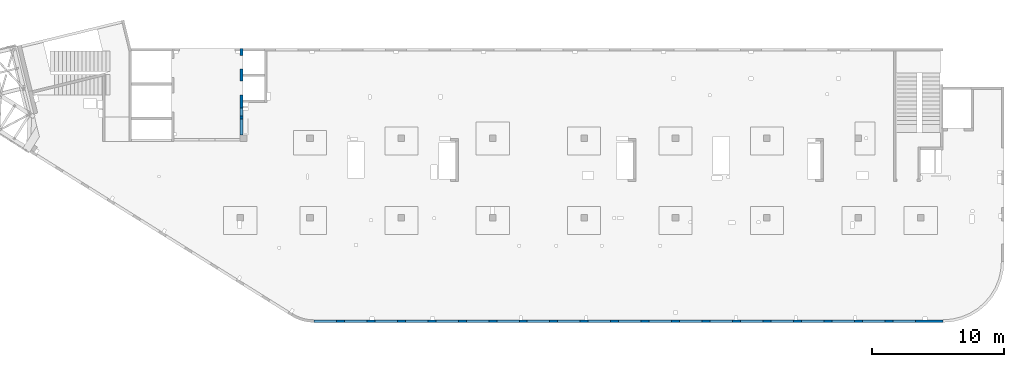
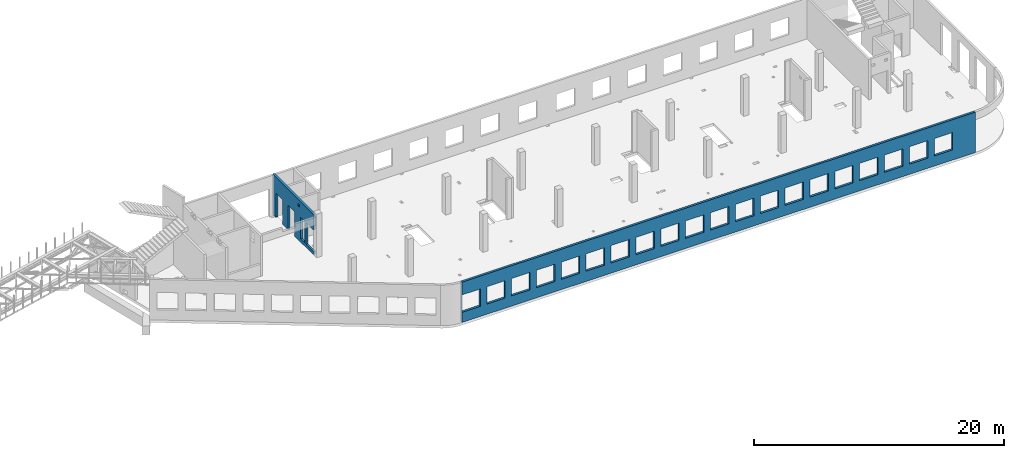
# One storey, part 65 of 66: 2 walls, 25 openings.
"""IFC4 building model written with IfcOpenShell, lengths in millimetres."""

from ifc_helpers import new_model, entity, si_unit, converted_unit, derived_unit, direction, frame, origin, place, context, subcontext, project, spatial, indexed_curve, outline, extrude, polygons, material, type_object, element, save


model = new_model("IFC4")

# Units and contexts
model_context = context("Model", 3, precision=0.01, world=origin(), true_north=direction((6.12303176911189e-17, 1.0)))
plan_context = context("Plan", 3, precision=0.01, world=origin(), true_north=direction((6.12303176911189e-17, 1.0)))
body_context = subcontext(model_context, "Body", "Model", "MODEL_VIEW")
ifc_project = project(units=[si_unit("LENGTHUNIT", "METRE", prefix="MILLI"), si_unit("AREAUNIT", "SQUARE_METRE"), si_unit("VOLUMEUNIT", "CUBIC_METRE"), converted_unit("PLANEANGLEUNIT", "DEGREE", entity("IfcRatioMeasure", 0.0174532925199433), si_unit("PLANEANGLEUNIT", "RADIAN"), dimensions=[0, 0, 0, 0, 0, 0, 0]), si_unit("MASSUNIT", "GRAM", prefix="KILO"), derived_unit("MASSDENSITYUNIT", [(si_unit("MASSUNIT", "GRAM", prefix="KILO"), 1), (si_unit("LENGTHUNIT", "METRE"), -3)]), derived_unit("MOMENTOFINERTIAUNIT", [(si_unit("LENGTHUNIT", "METRE"), 4)]), si_unit("TIMEUNIT", "SECOND"), si_unit("FREQUENCYUNIT", "HERTZ"), si_unit("THERMODYNAMICTEMPERATUREUNIT", "DEGREE_CELSIUS"), derived_unit("THERMALTRANSMITTANCEUNIT", [(si_unit("MASSUNIT", "GRAM", prefix="KILO"), 1), (si_unit("THERMODYNAMICTEMPERATUREUNIT", "KELVIN"), -1), (si_unit("TIMEUNIT", "SECOND"), -3)]), derived_unit("VOLUMETRICFLOWRATEUNIT", [(si_unit("LENGTHUNIT", "METRE"), 3), (si_unit("TIMEUNIT", "SECOND"), -1)]), derived_unit("MASSFLOWRATEUNIT", [(si_unit("MASSUNIT", "GRAM", prefix="KILO"), 1), (si_unit("TIMEUNIT", "SECOND"), -1)]), derived_unit("ROTATIONALFREQUENCYUNIT", [(si_unit("TIMEUNIT", "SECOND"), -1)]), si_unit("ELECTRICCURRENTUNIT", "AMPERE"), si_unit("ELECTRICVOLTAGEUNIT", "VOLT"), si_unit("POWERUNIT", "WATT"), si_unit("FORCEUNIT", "NEWTON", prefix="KILO"), si_unit("ILLUMINANCEUNIT", "LUX"), si_unit("LUMINOUSFLUXUNIT", "LUMEN"), si_unit("LUMINOUSINTENSITYUNIT", "CANDELA"), derived_unit("USERDEFINED", [(si_unit("MASSUNIT", "GRAM", prefix="KILO"), -1), (si_unit("LENGTHUNIT", "METRE"), -2), (si_unit("TIMEUNIT", "SECOND"), 3), (si_unit("LUMINOUSFLUXUNIT", "LUMEN"), 1)]), derived_unit("LINEARVELOCITYUNIT", [(si_unit("LENGTHUNIT", "METRE"), 1), (si_unit("TIMEUNIT", "SECOND"), -1)]), si_unit("PRESSUREUNIT", "PASCAL"), derived_unit("USERDEFINED", [(si_unit("LENGTHUNIT", "METRE"), -2), (si_unit("MASSUNIT", "GRAM", prefix="KILO"), 1), (si_unit("TIMEUNIT", "SECOND"), -2)]), derived_unit("LINEARFORCEUNIT", [(si_unit("MASSUNIT", "GRAM", prefix="KILO"), 1), (si_unit("LENGTHUNIT", "METRE"), 1), (si_unit("TIMEUNIT", "SECOND"), -2), (si_unit("LENGTHUNIT", "METRE"), -1)]), derived_unit("PLANARFORCEUNIT", [(si_unit("MASSUNIT", "GRAM", prefix="KILO"), 1), (si_unit("LENGTHUNIT", "METRE"), 1), (si_unit("TIMEUNIT", "SECOND"), -2), (si_unit("LENGTHUNIT", "METRE"), -2)])], contexts=[model_context, plan_context])

# Site, building, storey
site_placement = place(None, origin())
site = spatial("IfcSite", under=ifc_project, at=site_placement, CompositionType="ELEMENT")
building_placement = place(site_placement, origin())
building = spatial("IfcBuilding", under=site, at=building_placement, CompositionType="ELEMENT")
storey_placement = place(building_placement, frame((0.0, 0.0, 19800.0)))
storey = spatial("IfcBuildingStorey", under=building, at=storey_placement, Name="06", CompositionType="ELEMENT", Elevation=19800.0)

# Wall, openings
ifc_material = material()
wall_type = type_object("IfcWallType", Name=":ADSK_ 25_200", PredefinedType="STANDARD")
wall_1_placement = place(storey_placement, frame((21465.0, -100.0, -150.0)))
wall_1 = element("IfcWall", 1, at=wall_1_placement, inside=storey, type_object=wall_type, material=ifc_material, Name=":ADSK_ 25_200", ObjectType=":ADSK_ 25_200", PredefinedType="NOTDEFINED", context=body_context, shape_type="Tessellation", body=[
    polygons([(43705.0, -100.0, 2700.0), (45405.0, -100.0, 2700.0), (45405.0, -100.0, 1000.00000000001), (43705.0, -100.0, 1000.00000000001), (41405.0, -100.0, 2700.0), (43105.0, -100.0, 2700.0), (43105.0, -100.0, 1000.00000000001), (41405.0, -100.0, 1000.00000000001), (39105.0, -100.0, 2700.0), (40805.0, -100.0, 2700.0), (40805.0, -100.0, 1000.00000000001), (39105.0, -100.0, 1000.00000000001), (36805.0, -100.0, 2700.0), (38505.0, -100.0, 2700.0), (38505.0, -100.0, 1000.00000000001), (36805.0, -100.0, 1000.00000000001), (34505.0, -100.0, 2700.0), (36205.0, -100.0, 2700.0), (36205.0, -100.0, 1000.00000000001), (34505.0, -100.0, 1000.00000000001), (27605.0, -100.0, 2700.0), (29305.0, -100.0, 2700.0), (29305.0, -100.0, 1000.00000000001), (27605.0, -100.0, 1000.00000000001), (29905.0, -100.0, 2700.0), (31605.0, -100.0, 2700.0), (31605.0, -100.0, 1000.00000000001), (29905.0, -100.0, 1000.00000000001), (32205.0, -100.0, 2700.0), (33905.0, -100.0, 2700.0), (33905.0, -100.0, 1000.00000000001), (32205.0, -100.0, 1000.00000000001), (20705.0, -100.0, 2700.0), (22405.0, -100.0, 2700.0), (22405.0, -100.0, 1000.00000000001), (20705.0, -100.0, 1000.00000000001), (23005.0, -100.0, 2700.0), (24705.0, -100.0, 2700.0), (24705.0, -100.0, 1000.00000000001), (23005.0, -100.0, 1000.00000000001), (25305.0, -100.0, 2700.0), (27005.0, -100.0, 2700.0), (27005.0, -100.0, 1000.00000000001), (25305.0, -100.0, 1000.00000000001), (13805.0, -100.0, 2700.0), (15505.0, -100.0, 2700.0), (15505.0, -100.0, 1000.00000000001), (13805.0, -100.0, 1000.00000000001), (16105.0, -100.0, 2700.0), (17805.0, -100.0, 2700.0), (17805.0, -100.0, 1000.00000000001), (16105.0, -100.0, 1000.00000000001), (18405.0, -100.0, 2700.0), (20105.0, -100.0, 2700.0), (20105.0, -100.0, 1000.00000000001), (18405.0, -100.0, 1000.00000000001), (6904.99999999999, -100.0, 2700.0), (8604.99999999999, -100.0, 2700.0), (8604.99999999999, -100.0, 1000.00000000001), (6904.99999999999, -100.0, 1000.00000000001), (9205.0, -100.0, 2700.0), (10905.0, -100.0, 2700.0), (10905.0, -100.0, 1000.00000000001), (9205.0, -100.0, 1000.00000000001), (11505.0, -100.0, 2700.0), (13205.0, -100.0, 2700.0), (13205.0, -100.0, 1000.00000000001), (11505.0, -100.0, 1000.00000000001), (2305.0, -100.0, 2700.0), (4005.0, -100.0, 2700.0), (4005.0, -100.0, 1000.00000000001), (2305.0, -100.0, 1000.00000000001), (4605.0, -100.0, 2700.0), (6305.00000000001, -100.0, 2700.0), (6305.00000000001, -100.0, 1000.00000000001), (4605.0, -100.0, 1000.00000000001), (5.00000000000384, -100.0, 2700.0), (1705.0, -100.0, 2700.0), (1705.0, -100.0, 1000.00000000001), (5.00000000000384, -100.0, 1000.00000000001), (6.46235172450444e-13, -100.0, 0.0), (47505.0, -100.0, 0.0), (47505.0, -100.0, 3950.0), (4.65284088467406, -100.0, 3950.0), (4.97770368964401e-12, -100.0, 3950.0), (45405.0, 100.000000000321, 2700.0), (43705.0, 100.000000000321, 2700.0), (43705.0, 100.000000000321, 1000.00000000001), (45405.0, 100.000000000321, 1000.00000000001), (43105.0, 100.000000000321, 2700.0), (41405.0, 100.000000000321, 2700.0), (41405.0, 100.000000000321, 1000.00000000001), (43105.0, 100.000000000321, 1000.00000000001), (40805.0, 100.000000000321, 2700.0), (39105.0, 100.000000000321, 2700.0), (39105.0, 100.000000000321, 1000.00000000001), (40805.0, 100.000000000321, 1000.00000000001), (38505.0, 100.000000000321, 2700.0), (36805.0, 100.000000000321, 2700.0), (36805.0, 100.000000000321, 1000.00000000001), (38505.0, 100.000000000321, 1000.00000000001), (36205.0, 100.000000000321, 2700.0), (34505.0, 100.000000000321, 2700.0), (34505.0, 100.000000000321, 1000.00000000001), (36205.0, 100.000000000321, 1000.00000000001), (29305.0, 100.000000000321, 2700.0), (27605.0, 100.000000000321, 2700.0), (27605.0, 100.000000000321, 1000.00000000001), (29305.0, 100.000000000321, 1000.00000000001), (31605.0, 100.000000000321, 2700.0), (29905.0, 100.000000000321, 2700.0), (29905.0, 100.000000000321, 1000.00000000001), (31605.0, 100.000000000321, 1000.00000000001), (33905.0, 100.000000000321, 2700.0), (32205.0, 100.000000000321, 2700.0), (32205.0, 100.000000000321, 1000.00000000001), (33905.0, 100.000000000321, 1000.00000000001), (22405.0, 100.000000000321, 2700.0), (20705.0, 100.000000000321, 2700.0), (20705.0, 100.000000000321, 1000.00000000001), (22405.0, 100.000000000321, 1000.00000000001), (24705.0, 100.000000000321, 2700.0), (23005.0, 100.000000000321, 2700.0), (23005.0, 100.000000000321, 1000.00000000001), (24705.0, 100.000000000321, 1000.00000000001), (27005.0, 100.000000000321, 2700.0), (25305.0, 100.000000000321, 2700.0), (25305.0, 100.000000000321, 1000.00000000001), (27005.0, 100.000000000321, 1000.00000000001), (15505.0, 100.000000000321, 2700.0), (13805.0, 100.000000000321, 2700.0), (13805.0, 100.000000000321, 1000.00000000001), (15505.0, 100.000000000321, 1000.00000000001), (17805.0, 100.000000000321, 2700.0), (16105.0, 100.000000000321, 2700.0), (16105.0, 100.000000000321, 1000.00000000001), (17805.0, 100.000000000321, 1000.00000000001), (20105.0, 100.000000000321, 2700.0), (18405.0, 100.000000000321, 2700.0), (18405.0, 100.000000000321, 1000.00000000001), (20105.0, 100.000000000321, 1000.00000000001), (8604.99999999998, 100.000000000321, 2700.0), (6904.99999999999, 100.000000000321, 2700.0), (6904.99999999999, 100.000000000321, 1000.00000000001), (8604.99999999998, 100.000000000321, 1000.00000000001), (10905.0, 100.000000000321, 2700.0), (9204.99999999999, 100.000000000321, 2700.0), (9204.99999999999, 100.000000000321, 1000.00000000001), (10905.0, 100.000000000321, 1000.00000000001), (13205.0, 100.000000000321, 2700.0), (11505.0, 100.000000000321, 2700.0), (11505.0, 100.000000000321, 1000.00000000001), (13205.0, 100.000000000321, 1000.00000000001), (4005.0, 100.000000000321, 2700.0), (2305.0, 100.000000000321, 2700.0), (2305.0, 100.000000000321, 1000.00000000001), (4005.0, 100.000000000321, 1000.00000000001), (6305.0, 100.000000000321, 2700.0), (4605.0, 100.000000000321, 2700.0), (4605.0, 100.000000000321, 1000.00000000001), (6305.0, 100.000000000321, 1000.00000000001), (1705.0, 100.000000000321, 2700.0), (5.00000000000319, 100.000000000321, 2700.0), (5.00000000000319, 100.000000000321, 1000.00000000002), (1705.0, 100.000000000321, 1000.00000000002), (47505.0, 100.0, 0.0), (46305.0, 100.0, 0.0), (46005.0, 100.0, 0.0), (40985.0, 100.0, 0.0), (40785.0, 100.0, 0.0), (36475.0, 100.0, 0.0), (36275.0, 100.0, 0.0), (31965.0, 100.0, 0.0), (31765.0, 100.0, 0.0), (20675.0, 100.0, 0.0), (20475.0, 100.0, 0.0), (15725.0, 100.0, 0.0), (15525.0, 100.0, 0.0), (9114.99999999999, 100.0, 0.0), (8814.99999999999, 100.0, 0.0), (4534.99999999999, 100.0, 0.0), (4234.99999999999, 100.0, 0.0), (2.49977157936766e-18, 100.0, 0.0), (4.33147101696515e-12, 100.0, 3950.0), (4234.99999999999, 100.0, 3950.0), (4535.0, 100.0, 3950.0), (8930.0, 100.0, 3950.0), (9130.0, 100.0, 3950.0), (13355.0, 100.0, 3950.0), (13655.0, 100.0, 3950.0), (18105.0, 100.0, 3950.0), (18405.0, 100.0, 3950.0), (24805.0, 100.0, 3950.0), (25105.0, 100.0, 3950.0), (31805.0, 100.0, 3950.0), (32105.0, 100.0, 3950.0), (36405.0, 100.0, 3950.0), (36705.0, 100.0, 3950.0), (41005.0, 100.0, 3950.0), (41305.0, 100.0, 3950.0), (46005.0, 100.0, 3950.0), (46305.0, 100.0, 3950.0), (47505.0, 100.0, 3950.0)], [[[81, 82, 83, 84, 85], [1, 2, 3, 4], [5, 6, 7, 8], [9, 10, 11, 12], [13, 14, 15, 16], [17, 18, 19, 20], [21, 22, 23, 24], [25, 26, 27, 28], [29, 30, 31, 32], [33, 34, 35, 36], [37, 38, 39, 40], [41, 42, 43, 44], [45, 46, 47, 48], [49, 50, 51, 52], [53, 54, 55, 56], [57, 58, 59, 60], [61, 62, 63, 64], [65, 66, 67, 68], [69, 70, 71, 72], [73, 74, 75, 76], [77, 78, 79, 80]], [[166, 167, 168, 169, 170, 171, 172, 173, 174, 175, 176, 177, 178, 179, 180, 181, 182, 183, 184, 185, 186, 187, 188, 189, 190, 191, 192, 193, 194, 195, 196, 197, 198, 199, 200, 201, 202, 203], [86, 87, 88, 89], [90, 91, 92, 93], [94, 95, 96, 97], [98, 99, 100, 101], [102, 103, 104, 105], [106, 107, 108, 109], [110, 111, 112, 113], [114, 115, 116, 117], [118, 119, 120, 121], [122, 123, 124, 125], [126, 127, 128, 129], [130, 131, 132, 133], [134, 135, 136, 137], [138, 139, 140, 141], [142, 143, 144, 145], [146, 147, 148, 149], [150, 151, 152, 153], [154, 155, 156, 157], [158, 159, 160, 161], [162, 163, 164, 165]], [[82, 81, 183, 182, 181, 180, 179, 178, 177, 176, 175, 174, 173, 172, 171, 170, 169, 168, 167, 166]], [[83, 82, 166, 203]], [[85, 84, 83, 203, 202, 201, 200, 199, 198, 197, 196, 195, 194, 193, 192, 191, 190, 189, 188, 187, 186, 185, 184]], [[81, 85, 184, 183]], [[87, 86, 2, 1]], [[87, 1, 4, 88]], [[88, 4, 3, 89]], [[2, 86, 89, 3]], [[91, 90, 6, 5]], [[91, 5, 8, 92]], [[92, 8, 7, 93]], [[6, 90, 93, 7]], [[95, 94, 10, 9]], [[95, 9, 12, 96]], [[96, 12, 11, 97]], [[10, 94, 97, 11]], [[99, 98, 14, 13]], [[99, 13, 16, 100]], [[100, 16, 15, 101]], [[14, 98, 101, 15]], [[103, 102, 18, 17]], [[103, 17, 20, 104]], [[104, 20, 19, 105]], [[18, 102, 105, 19]], [[107, 106, 22, 21]], [[107, 21, 24, 108]], [[108, 24, 23, 109]], [[22, 106, 109, 23]], [[111, 110, 26, 25]], [[111, 25, 28, 112]], [[112, 28, 27, 113]], [[26, 110, 113, 27]], [[115, 114, 30, 29]], [[115, 29, 32, 116]], [[116, 32, 31, 117]], [[30, 114, 117, 31]], [[119, 118, 34, 33]], [[119, 33, 36, 120]], [[120, 36, 35, 121]], [[34, 118, 121, 35]], [[123, 122, 38, 37]], [[123, 37, 40, 124]], [[124, 40, 39, 125]], [[38, 122, 125, 39]], [[127, 126, 42, 41]], [[127, 41, 44, 128]], [[128, 44, 43, 129]], [[42, 126, 129, 43]], [[131, 130, 46, 45]], [[131, 45, 48, 132]], [[132, 48, 47, 133]], [[46, 130, 133, 47]], [[135, 134, 50, 49]], [[135, 49, 52, 136]], [[136, 52, 51, 137]], [[50, 134, 137, 51]], [[139, 138, 54, 53]], [[139, 53, 56, 140]], [[140, 56, 55, 141]], [[54, 138, 141, 55]], [[143, 142, 58, 57]], [[143, 57, 60, 144]], [[144, 60, 59, 145]], [[58, 142, 145, 59]], [[147, 146, 62, 61]], [[147, 61, 64, 148]], [[148, 64, 63, 149]], [[62, 146, 149, 63]], [[151, 150, 66, 65]], [[151, 65, 68, 152]], [[152, 68, 67, 153]], [[66, 150, 153, 67]], [[155, 154, 70, 69]], [[155, 69, 72, 156]], [[156, 72, 71, 157]], [[70, 154, 157, 71]], [[159, 158, 74, 73]], [[159, 73, 76, 160]], [[160, 76, 75, 161]], [[74, 158, 161, 75]], [[77, 163, 162, 78]], [[163, 77, 80, 164]], [[164, 80, 79, 165]], [[78, 162, 165, 79]]], closed=True),
])
placement_1 = place(wall_1_placement, frame((-21465.0, 100.0, 150.0)))
element("IfcOpeningElement", 2, at=placement_1, cuts=wall_1, Name=":ADSK_ 25_200", PredefinedType="OPENING", context=body_context, shape_type="SweptSolid", body=[
    extrude(outline(indexed_curve([(-849.999999999993, -850.000000000002), (849.999999999993, -850.000000000002), (849.999999999993, 849.999999999997), (-849.999999999993, 849.999999999997), (-849.999999999993, -850.000000000002)], self_intersect=False)), frame((22320.0, -200.0, 1700.0), z_axis=(0.0, 1.0, 0.0), x_axis=(0.0, 0.0, -1.0)), (0.0, 0.0, 1.0), 200.000000000962),
])
element("IfcOpeningElement", 3, at=placement_1, cuts=wall_1, Name=":ADSK_ 25_200", PredefinedType="OPENING", context=body_context, shape_type="SweptSolid", body=[
    extrude(outline(indexed_curve([(-849.999999999993, -850.000000000006), (849.999999999993, -850.000000000006), (849.999999999993, 849.999999999997), (-849.999999999993, 849.999999999997), (-849.999999999993, -850.000000000006)], self_intersect=False)), frame((66020.0, -200.0, 1700.0), z_axis=(0.0, 1.0, 0.0), x_axis=(0.0, 0.0, -1.0)), (0.0, 0.0, 1.0), 200.000000000962),
])
element("IfcOpeningElement", 4, at=placement_1, cuts=wall_1, Name=":ADSK_ 25_200", PredefinedType="OPENING", context=body_context, shape_type="SweptSolid", body=[
    extrude(outline(indexed_curve([(-849.999999999993, -850.000000000006), (849.999999999993, -850.000000000006), (849.999999999993, 849.999999999997), (-849.999999999993, 849.999999999997), (-849.999999999993, -850.000000000006)], self_intersect=False)), frame((63720.0, -200.0, 1700.0), z_axis=(0.0, 1.0, 0.0), x_axis=(0.0, 0.0, -1.0)), (0.0, 0.0, 1.0), 200.000000000962),
])
element("IfcOpeningElement", 5, at=placement_1, cuts=wall_1, Name=":ADSK_ 25_200", PredefinedType="OPENING", context=body_context, shape_type="SweptSolid", body=[
    extrude(outline(indexed_curve([(-849.999999999993, -850.000000000006), (849.999999999993, -850.000000000006), (849.999999999993, 849.999999999997), (-849.999999999993, 849.999999999997), (-849.999999999993, -850.000000000006)], self_intersect=False)), frame((61420.0, -200.0, 1700.0), z_axis=(0.0, 1.0, 0.0), x_axis=(0.0, 0.0, -1.0)), (0.0, 0.0, 1.0), 200.000000000962),
])
element("IfcOpeningElement", 6, at=placement_1, cuts=wall_1, Name=":ADSK_ 25_200", PredefinedType="OPENING", context=body_context, shape_type="SweptSolid", body=[
    extrude(outline(indexed_curve([(-849.999999999993, -849.999999999997), (849.999999999993, -849.999999999997), (849.999999999993, 850.000000000006), (-849.999999999993, 850.000000000006), (-849.999999999993, -849.999999999997)], self_intersect=False)), frame((59120.0, -200.0, 1700.0), z_axis=(0.0, 1.0, 0.0), x_axis=(0.0, 0.0, -1.0)), (0.0, 0.0, 1.0), 200.000000000962),
])
element("IfcOpeningElement", 7, at=placement_1, cuts=wall_1, Name=":ADSK_ 25_200", PredefinedType="OPENING", context=body_context, shape_type="SweptSolid", body=[
    extrude(outline(indexed_curve([(-849.999999999993, -850.000000000006), (849.999999999993, -850.000000000006), (849.999999999993, 849.999999999997), (-849.999999999993, 849.999999999997), (-849.999999999993, -850.000000000006)], self_intersect=False)), frame((56820.0, -200.0, 1700.0), z_axis=(0.0, 1.0, 0.0), x_axis=(0.0, 0.0, -1.0)), (0.0, 0.0, 1.0), 200.000000000962),
])
element("IfcOpeningElement", 8, at=placement_1, cuts=wall_1, Name=":ADSK_ 25_200", PredefinedType="OPENING", context=body_context, shape_type="SweptSolid", body=[
    extrude(outline(indexed_curve([(-849.999999999993, -849.999999999997), (849.999999999993, -849.999999999997), (849.999999999993, 850.000000000006), (-849.999999999993, 850.000000000006), (-849.999999999993, -849.999999999997)], self_intersect=False)), frame((54520.0, -200.0, 1700.0), z_axis=(0.0, 1.0, 0.0), x_axis=(0.0, 0.0, -1.0)), (0.0, 0.0, 1.0), 200.000000000962),
])
element("IfcOpeningElement", 9, at=placement_1, cuts=wall_1, Name=":ADSK_ 25_200", PredefinedType="OPENING", context=body_context, shape_type="SweptSolid", body=[
    extrude(outline(indexed_curve([(-849.999999999993, -850.000000000006), (849.999999999993, -850.000000000006), (849.999999999993, 849.999999999997), (-849.999999999993, 849.999999999997), (-849.999999999993, -850.000000000006)], self_intersect=False)), frame((52220.0, -200.0, 1700.0), z_axis=(0.0, 1.0, 0.0), x_axis=(0.0, 0.0, -1.0)), (0.0, 0.0, 1.0), 200.000000000962),
])
element("IfcOpeningElement", 10, at=placement_1, cuts=wall_1, Name=":ADSK_ 25_200", PredefinedType="OPENING", context=body_context, shape_type="SweptSolid", body=[
    extrude(outline(indexed_curve([(-849.999999999993, -850.000000000006), (849.999999999993, -850.000000000006), (849.999999999993, 849.999999999997), (-849.999999999993, 849.999999999997), (-849.999999999993, -850.000000000006)], self_intersect=False)), frame((49920.0, -200.0, 1700.0), z_axis=(0.0, 1.0, 0.0), x_axis=(0.0, 0.0, -1.0)), (0.0, 0.0, 1.0), 200.000000000962),
])
element("IfcOpeningElement", 11, at=placement_1, cuts=wall_1, Name=":ADSK_ 25_200", PredefinedType="OPENING", context=body_context, shape_type="SweptSolid", body=[
    extrude(outline(indexed_curve([(-849.999999999993, -850.000000000006), (849.999999999993, -850.000000000006), (849.999999999993, 849.999999999997), (-849.999999999993, 849.999999999997), (-849.999999999993, -850.000000000006)], self_intersect=False)), frame((47620.0, -200.0, 1700.0), z_axis=(0.0, 1.0, 0.0), x_axis=(0.0, 0.0, -1.0)), (0.0, 0.0, 1.0), 200.000000000962),
])
element("IfcOpeningElement", 12, at=placement_1, cuts=wall_1, Name=":ADSK_ 25_200", PredefinedType="OPENING", context=body_context, shape_type="SweptSolid", body=[
    extrude(outline(indexed_curve([(-849.999999999993, -850.000000000006), (849.999999999993, -850.000000000006), (849.999999999993, 849.999999999997), (-849.999999999993, 849.999999999997), (-849.999999999993, -850.000000000006)], self_intersect=False)), frame((45320.0, -200.0, 1700.0), z_axis=(0.0, 1.0, 0.0), x_axis=(0.0, 0.0, -1.0)), (0.0, 0.0, 1.0), 200.000000000962),
])
element("IfcOpeningElement", 13, at=placement_1, cuts=wall_1, Name=":ADSK_ 25_200", PredefinedType="OPENING", context=body_context, shape_type="SweptSolid", body=[
    extrude(outline(indexed_curve([(-849.999999999993, -849.999999999997), (849.999999999993, -849.999999999997), (849.999999999993, 850.000000000006), (-849.999999999993, 850.000000000006), (-849.999999999993, -849.999999999997)], self_intersect=False)), frame((43020.0, -200.0, 1700.0), z_axis=(0.0, 1.0, 0.0), x_axis=(0.0, 0.0, -1.0)), (0.0, 0.0, 1.0), 200.000000000962),
])
element("IfcOpeningElement", 14, at=placement_1, cuts=wall_1, Name=":ADSK_ 25_200", PredefinedType="OPENING", context=body_context, shape_type="SweptSolid", body=[
    extrude(outline(indexed_curve([(-849.999999999993, -850.000000000006), (849.999999999993, -850.000000000006), (849.999999999993, 849.999999999997), (-849.999999999993, 849.999999999997), (-849.999999999993, -850.000000000006)], self_intersect=False)), frame((40720.0, -200.0, 1700.0), z_axis=(0.0, 1.0, 0.0), x_axis=(0.0, 0.0, -1.0)), (0.0, 0.0, 1.0), 200.000000000962),
])
element("IfcOpeningElement", 15, at=placement_1, cuts=wall_1, Name=":ADSK_ 25_200", PredefinedType="OPENING", context=body_context, shape_type="SweptSolid", body=[
    extrude(outline(indexed_curve([(-849.999999999993, -850.000000000002), (849.999999999993, -850.000000000002), (849.999999999993, 850.000000000002), (-849.999999999993, 850.000000000002), (-849.999999999993, -850.000000000002)], self_intersect=False)), frame((38420.0, -200.0, 1700.0), z_axis=(0.0, 1.0, 0.0), x_axis=(0.0, 0.0, -1.0)), (0.0, 0.0, 1.0), 200.000000000962),
])
element("IfcOpeningElement", 16, at=placement_1, cuts=wall_1, Name=":ADSK_ 25_200", PredefinedType="OPENING", context=body_context, shape_type="SweptSolid", body=[
    extrude(outline(indexed_curve([(-849.999999999993, -849.999999999997), (849.999999999993, -849.999999999997), (849.999999999993, 850.000000000002), (-849.999999999993, 850.000000000002), (-849.999999999993, -849.999999999997)], self_intersect=False)), frame((36120.0, -200.0, 1700.0), z_axis=(0.0, 1.0, 0.0), x_axis=(0.0, 0.0, -1.0)), (0.0, 0.0, 1.0), 200.000000000962),
])
element("IfcOpeningElement", 17, at=placement_1, cuts=wall_1, Name=":ADSK_ 25_200", PredefinedType="OPENING", context=body_context, shape_type="SweptSolid", body=[
    extrude(outline(indexed_curve([(-849.999999999993, -850.000000000002), (849.999999999993, -850.000000000002), (849.999999999993, 849.999999999997), (-849.999999999993, 849.999999999997), (-849.999999999993, -850.000000000002)], self_intersect=False)), frame((33820.0, -200.0, 1700.0), z_axis=(0.0, 1.0, 0.0), x_axis=(0.0, 0.0, -1.0)), (0.0, 0.0, 1.0), 200.000000000962),
])
element("IfcOpeningElement", 18, at=placement_1, cuts=wall_1, Name=":ADSK_ 25_200", PredefinedType="OPENING", context=body_context, shape_type="SweptSolid", body=[
    extrude(outline(indexed_curve([(-849.999999999993, -850.000000000002), (849.999999999993, -850.000000000002), (849.999999999993, 849.999999999997), (-849.999999999993, 849.999999999997), (-849.999999999993, -850.000000000002)], self_intersect=False)), frame((31520.0, -200.0, 1700.0), z_axis=(0.0, 1.0, 0.0), x_axis=(0.0, 0.0, -1.0)), (0.0, 0.0, 1.0), 200.000000000962),
])
element("IfcOpeningElement", 19, at=placement_1, cuts=wall_1, Name=":ADSK_ 25_200", PredefinedType="OPENING", context=body_context, shape_type="SweptSolid", body=[
    extrude(outline(indexed_curve([(-849.999999999993, -850.000000000002), (849.999999999993, -850.000000000002), (849.999999999993, 849.999999999997), (-849.999999999993, 849.999999999997), (-849.999999999993, -850.000000000002)], self_intersect=False)), frame((29220.0, -200.0, 1700.0), z_axis=(0.0, 1.0, 0.0), x_axis=(0.0, 0.0, -1.0)), (0.0, 0.0, 1.0), 200.000000000962),
])
element("IfcOpeningElement", 20, at=placement_1, cuts=wall_1, Name=":ADSK_ 25_200", PredefinedType="OPENING", context=body_context, shape_type="SweptSolid", body=[
    extrude(outline(indexed_curve([(-849.999999999993, -850.000000000002), (849.999999999993, -850.000000000002), (849.999999999993, 849.999999999997), (-849.999999999993, 849.999999999997), (-849.999999999993, -850.000000000002)], self_intersect=False)), frame((26920.0, -200.0, 1700.0), z_axis=(0.0, 1.0, 0.0), x_axis=(0.0, 0.0, -1.0)), (0.0, 0.0, 1.0), 200.000000000962),
])
element("IfcOpeningElement", 21, at=placement_1, cuts=wall_1, Name=":ADSK_ 25_200", PredefinedType="OPENING", context=body_context, shape_type="SweptSolid", body=[
    extrude(outline(indexed_curve([(-849.999999999993, -850.000000000002), (849.999999999993, -850.000000000002), (849.999999999993, 849.999999999997), (-849.999999999993, 849.999999999997), (-849.999999999993, -850.000000000002)], self_intersect=False)), frame((24620.0, -200.0, 1700.0), z_axis=(0.0, 1.0, 0.0), x_axis=(0.0, 0.0, -1.0)), (0.0, 0.0, 1.0), 200.000000000962),
])

wall_2_placement = place(storey_placement, frame((16000.0, 20500.0, -150.0), z_axis=(0.0, 0.0, 1.0), x_axis=(0.0, -1.0, 0.0)))
wall_2 = element("IfcWall", 22, at=wall_2_placement, inside=storey, type_object=wall_type, material=ifc_material, Name=":ADSK_ 25_200", ObjectType=":ADSK_ 25_200", PredefinedType="NOTDEFINED", context=body_context, shape_type="Tessellation", body=[
    polygons([(4100.00063936683, -100.000000000321, 3550.0), (4300.00063936683, -100.00000000032, 3550.0), (4300.00063936683, -100.00000000032, 3300.00000000001), (4100.00063936683, -100.000000000321, 3300.00000000001), (4500.00063936683, -100.000000000002, 2399.99999999998), (5100.00063936683, -100.000000000001, 2399.99999999999), (5100.00063936683, -100.000000000001, 300.000000000001), (4500.00063936683, -100.000000000002, 300.000000000001), (6550.00048980714, -99.999999999998, 3950.0), (399.999999999996, -100.0, 3950.0), (199.999999999998, -100.000000000001, 3950.0), (0.0, -100.000000000001, 3950.0), (0.0, -100.000000000001, 0.0), (199.999999999998, -100.000000000001, 0.0), (529.999999999996, -100.0, 0.0), (529.999999999996, -100.0, 2369.99999999804), (1570.0, -100.000000000003, 2369.99999999805), (1570.0, -100.000000000003, 0.0), (2480.0, -100.000000000001, 0.0), (2480.0, -100.000000000001, 2369.99999999804), (3519.99999999999, -100.000000000001, 2369.99999999805), (3519.99999999999, -100.000000000001, 0.0), (6550.00048980714, -99.999999999998, 0.0), (6550.00048980714, -99.999999999998, 300.000000000001), (5350.00048980714, -100.0, 300.000000000001), (5350.00048980714, -100.0, 2399.99999999998), (6550.00048980714, -99.999999999998, 2399.99999999999), (4300.00063936683, 100.0, 3550.0), (4100.00063936683, 99.9999999999998, 3550.0), (4100.00063936683, 99.9999999999998, 3300.00000000001), (4300.00063936683, 100.0, 3300.00000000001), (5100.00063936683, 99.9999999999994, 2399.99999999999), (4500.00063936683, 99.9999999999983, 2399.99999999998), (4500.00063936683, 99.9999999999983, 300.000000000001), (5100.00063936683, 99.9999999999994, 300.000000000001), (0.0, 99.9999999999989, 3950.0), (1950.0, 100.0, 3950.0), (2150.0, 99.9999999999984, 3950.0), (3900.00063936683, 99.9999999999994, 3950.0), (4100.00063936683, 99.9999999999998, 3950.0), (4300.00063936683, 100.0, 3950.0), (4525.00063936684, 99.9999999999984, 3950.0), (4685.00063936683, 99.9999999999986, 3950.0), (5340.00063936683, 99.9999999999998, 3950.0), (6530.00063936683, 99.9999999999998, 3950.0), (6550.00048980714, 99.9999999999998, 3950.0), (6550.00048980714, 99.9999999999998, 2399.99999999999), (5350.00048980714, 99.9999999999998, 2399.99999999998), (5350.00048980714, 99.9999999999998, 300.000000000001), (6550.00048980714, 99.9999999999998, 300.000000000001), (6550.00048980714, 99.9999999999998, 0.0), (4100.00063936683, 99.9999999999998, 0.0), (3900.00063936683, 99.9999999999994, 0.0), (3519.99999999999, 99.9999999999987, 0.0), (3519.99999999999, 99.9999999999987, 2369.99999999805), (2480.0, 100.000000000001, 2369.99999999804), (2480.0, 100.000000000001, 0.0), (1570.0, 99.9999999999995, 0.0), (1570.0, 99.9999999999995, 2369.99999999805), (529.999999999996, 99.9999999999998, 2369.99999999804), (529.999999999996, 99.9999999999998, 0.0), (0.0, 99.9999999999989, 0.0)], [[[9, 10, 11, 12, 13, 14, 15, 16, 17, 18, 19, 20, 21, 22, 23, 24, 25, 26, 27], [1, 2, 3, 4], [5, 6, 7, 8]], [[36, 37, 38, 39, 40, 41, 42, 43, 44, 45, 46, 47, 48, 49, 50, 51, 52, 53, 54, 55, 56, 57, 58, 59, 60, 61, 62], [28, 29, 30, 31], [32, 33, 34, 35]], [[15, 14, 13, 62, 61]], [[23, 51, 50, 24]], [[12, 11, 10, 9, 46, 45, 44, 43, 42, 41, 40, 39, 38, 37, 36]], [[59, 17, 16, 60]], [[60, 16, 15, 61]], [[17, 59, 58, 18]], [[55, 21, 20, 56]], [[56, 20, 19, 57]], [[21, 55, 54, 22]], [[26, 48, 47, 27]], [[25, 49, 48, 26]], [[49, 25, 24, 50]], [[2, 1, 29, 28]], [[2, 28, 31, 3]], [[3, 31, 30, 4]], [[29, 1, 4, 30]], [[32, 6, 5, 33]], [[33, 5, 8, 34]], [[34, 8, 7, 35]], [[6, 32, 35, 7]], [[13, 12, 36, 62]], [[46, 9, 27, 47]], [[18, 58, 57, 19]], [[51, 23, 22, 54, 53, 52]]], closed=True),
])
placement_2 = place(wall_2_placement, frame((20500.0, -16000.0, 150.0), z_axis=(0.0, 0.0, 1.0), x_axis=(0.0, 1.0, 0.0)))
element("IfcOpeningElement", 23, at=placement_2, cuts=wall_2, Name=":ADSK_ 25_200", PredefinedType="OPENING", context=body_context, shape_type="SweptSolid", body=[
    extrude(outline(indexed_curve([(-1184.99999999902, -519.999999999999), (1184.99999999902, -519.999999999999), (1184.99999999902, 520.000000000001), (-1184.99999999902, 520.000000000001), (-1184.99999999902, -519.999999999999)], self_intersect=False)), frame((15800.0, 19450.0, 1035.0), z_axis=(1.0, 0.0, 0.0), x_axis=(0.0, 0.0, -1.0)), (0.0, 0.0, 1.0), 400.000000001943),
])
element("IfcOpeningElement", 24, at=placement_2, cuts=wall_2, Name=":ADSK_ 25_200", PredefinedType="OPENING", context=body_context, shape_type="SweptSolid", body=[
    extrude(outline(indexed_curve([(-1184.99999999902, -520.000000000001), (1184.99999999902, -520.000000000001), (1184.99999999902, 519.999999999999), (-1184.99999999902, 519.999999999999), (-1184.99999999902, -520.000000000001)], self_intersect=False)), frame((15800.0, 17500.0, 1035.0), z_axis=(1.0, 0.0, 0.0), x_axis=(0.0, 0.0, -1.0)), (0.0, 0.0, 1.0), 400.000000001943),
])
element("IfcOpeningElement", 25, at=placement_2, cuts=wall_2, Name=":ADSK_ 25_200", PredefinedType="OPENING", context=body_context, shape_type="SweptSolid", body=[
    extrude(outline(indexed_curve([(-1049.99999999999, -600.0), (1050.0, -600.0), (1050.0, 600.0), (-1049.99999999999, 600.0), (-1049.99999999999, -600.0)], self_intersect=False)), frame((15800.0, 14550.0, 1200.0), z_axis=(1.0, 0.0, 0.0), x_axis=(0.0, 0.0, -1.0)), (0.0, 0.0, 1.0), 400.000000001943),
])
element("IfcOpeningElement", 26, at=placement_2, cuts=wall_2, Name=":ADSK_ 25_200", PredefinedType="OPENING", context=body_context, shape_type="SweptSolid", body=[
    extrude(outline(indexed_curve([(-100.000000000001, -124.999999999993), (99.9999999999989, -124.999999999993), (99.9999999999989, 124.999999999993), (-100.000000000001, 124.999999999993), (-100.000000000001, -124.999999999993)], self_intersect=False)), frame((15900.0, 16300.0, 3275.0), z_axis=(1.0, 0.0, 0.0), x_axis=(0.0, -1.0, 0.0)), (0.0, 0.0, 1.0), 200.000000000962),
])
element("IfcOpeningElement", 27, at=placement_2, cuts=wall_2, Name=":ADSK_ 25_200", PredefinedType="OPENING", context=body_context, shape_type="SweptSolid", body=[
    extrude(outline(indexed_curve([(-1049.99999999999, -300.000000000001), (1050.0, -300.000000000001), (1050.0, 299.999999999999), (-1049.99999999999, 299.999999999999), (-1049.99999999999, -300.000000000001)], self_intersect=False)), frame((15800.0, 15700.0, 1200.0), z_axis=(1.0, 0.0, 0.0), x_axis=(0.0, 0.0, -1.0)), (0.0, 0.0, 1.0), 400.000000001943),
])

save(model, "model.ifc")
